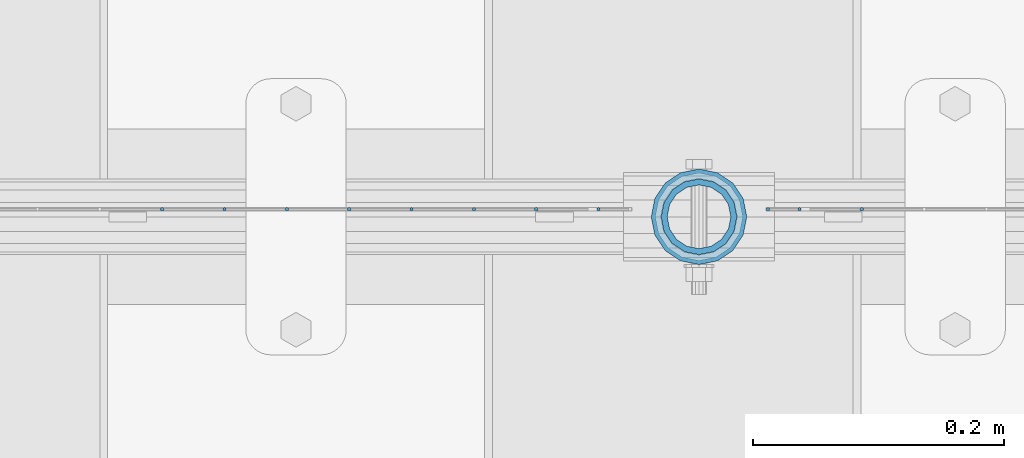
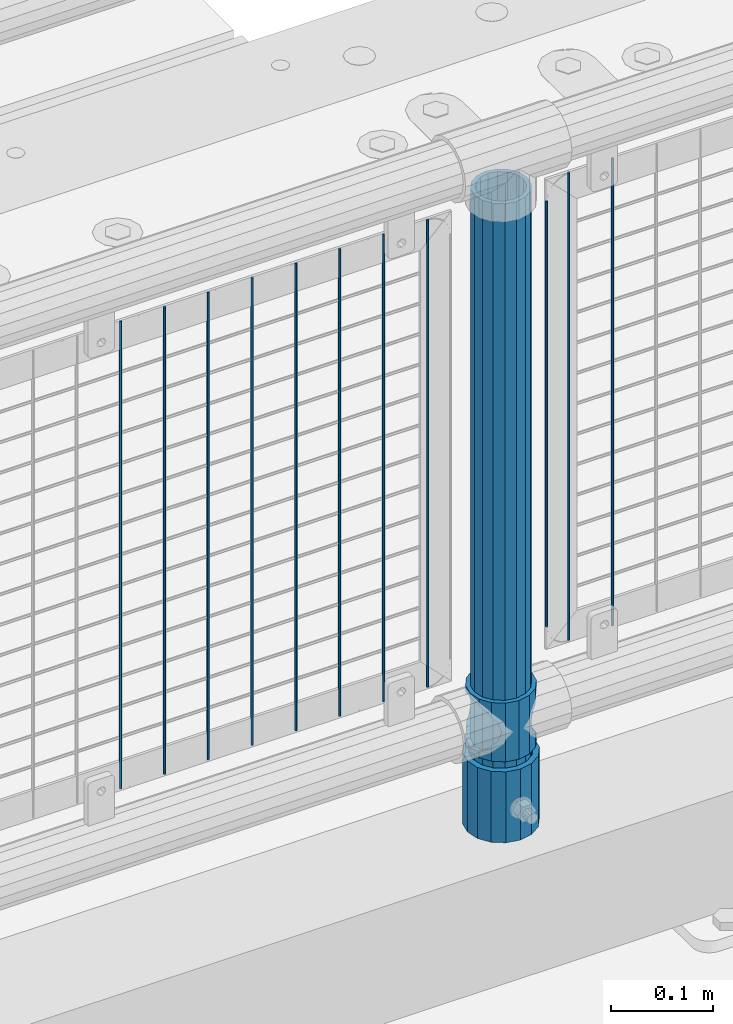
# One storey, part 77 of 208: 14 columns.
"""IFC2X3 building model written with IfcOpenShell, lengths in millimetres."""

from ifc_helpers import new_model, si_unit, frame, origin_with_axes, place, context, subcontext, project, spatial, faceted_brep, material, type_object, element, save


model = new_model("IFC2X3")

# Units and contexts
model_context = context("Model", 3, precision=1e-05, world=origin_with_axes())
body_context = subcontext(model_context, "Body", "Model", "MODEL_VIEW")
ifc_project = project(units=[si_unit("LENGTHUNIT", "METRE", prefix="MILLI"), si_unit("AREAUNIT", "SQUARE_METRE"), si_unit("VOLUMEUNIT", "CUBIC_METRE"), si_unit("MASSUNIT", "GRAM", prefix="KILO"), si_unit("TIMEUNIT", "SECOND"), si_unit("PLANEANGLEUNIT", "RADIAN"), si_unit("SOLIDANGLEUNIT", "STERADIAN"), si_unit("THERMODYNAMICTEMPERATUREUNIT", "DEGREE_CELSIUS"), si_unit("LUMINOUSINTENSITYUNIT", "LUMEN")], contexts=[model_context])

# Site, building, storey
site_placement = place(None, origin_with_axes())
site = spatial("IfcSite", under=ifc_project, at=site_placement, CompositionType="ELEMENT")
building_placement = place(site_placement, origin_with_axes())
building = spatial("IfcBuilding", under=site, at=building_placement, Name="Standard", CompositionType="ELEMENT")
storey_placement = place(building_placement, origin_with_axes())
storey = spatial("IfcBuildingStorey", under=building, at=storey_placement, Name="Undefined", CompositionType="ELEMENT", Elevation=0.0)

# Columns
ifc_material_1 = material()
column_type_1 = type_object("IfcColumnType", PredefinedType="NOTDEFINED")
column_1_placement = place(storey_placement, frame((-30629.0, 4664.5, 168.02), z_axis=(0.0, 1.0, 0.0), x_axis=(0.0, 0.0, 1.0)))
element("IfcColumn", 1, at=column_1_placement, inside=storey, type_object=column_type_1, material=ifc_material_1, context=body_context, shape_type="Brep", body=[
    faceted_brep([(0.0, -31.75, 0.0), (0.0, -29.3331751572332, 12.1501989775916), (85.0, -29.3331751572332, 12.1501989775916), (85.0, -31.75, 0.0), (0.0, -22.4506403026717, 22.4506403026726), (85.0, -22.4506403026717, 22.4506403026726), (0.0, -12.1501989775934, 29.3331751572332), (85.0, -12.1501989775934, 29.3331751572332), (0.0, 0.0, 31.75), (85.0, 0.0, 31.75), (0.0, 12.1501989775934, 29.3331751572332), (85.0, 12.1501989775934, 29.3331751572332), (0.0, 22.4506403026717, 22.4506403026726), (85.0, 22.4506403026717, 22.4506403026726), (0.0, 29.3331751572332, 12.1501989775916), (85.0, 29.3331751572332, 12.1501989775916), (0.0, 31.75, 0.0), (85.0, 31.75, 0.0), (0.0, 29.3331751572332, -12.1501989775916), (85.0, 29.3331751572332, -12.1501989775916), (0.0, 22.4506403026717, -22.4506403026726), (85.0, 22.4506403026717, -22.4506403026726), (0.0, 12.1501989775934, -29.3331751572332), (85.0, 12.1501989775934, -29.3331751572332), (0.0, 0.0, -31.75), (85.0, 0.0, -31.75), (0.0, -12.1501989775934, -29.3331751572332), (85.0, -12.1501989775934, -29.3331751572332), (0.0, -22.4506403026717, -22.4506403026726), (85.0, -22.4506403026717, -22.4506403026726), (0.0, -29.3331751572332, -12.1501989775916), (85.0, -29.3331751572332, -12.1501989775916), (0.0, -38.0499999999993, 0.0), (0.0, -35.1536162120537, -14.5611046014919), (85.0, -35.1536162120537, -14.5611046014919), (85.0, -38.0499999999993, 0.0), (0.0, -26.9054130241493, -26.9054130241484), (85.0, -26.9054130241493, -26.9054130241484), (0.0, -14.5611046014928, -35.1536162120547), (85.0, -14.5611046014928, -35.1536162120547), (0.0, 0.0, -38.0500000000002), (85.0, 0.0, -38.0500000000002), (0.0, 14.5611046014928, -35.1536162120547), (85.0, 14.5611046014928, -35.1536162120547), (0.0, 26.9054130241493, -26.9054130241484), (85.0, 26.9054130241493, -26.9054130241484), (0.0, 35.1536162120537, -14.5611046014919), (85.0, 35.1536162120537, -14.5611046014919), (0.0, 38.0499999999993, 0.0), (85.0, 38.0499999999993, 0.0), (0.0, 35.1536162120537, 14.5611046014919), (85.0, 35.1536162120537, 14.5611046014919), (0.0, 26.9054130241493, 26.9054130241484), (85.0, 26.9054130241493, 26.9054130241484), (0.0, 14.5611046014928, 35.1536162120547), (85.0, 14.5611046014928, 35.1536162120547), (0.0, 0.0, 38.0500000000002), (85.0, 0.0, 38.0500000000002), (0.0, -14.5611046014928, 35.1536162120547), (85.0, -14.5611046014928, 35.1536162120547), (0.0, -26.9054130241493, 26.9054130241484), (85.0, -26.9054130241493, 26.9054130241484), (0.0, -35.1536162120537, 14.5611046014919), (85.0, -35.1536162120537, 14.5611046014919)], [[[0, 1, 2, 3]], [[1, 4, 5, 2]], [[4, 6, 7, 5]], [[6, 8, 9, 7]], [[8, 10, 11, 9]], [[10, 12, 13, 11]], [[12, 14, 15, 13]], [[14, 16, 17, 15]], [[16, 18, 19, 17]], [[18, 20, 21, 19]], [[20, 22, 23, 21]], [[22, 24, 25, 23]], [[24, 26, 27, 25]], [[26, 28, 29, 27]], [[28, 30, 31, 29]], [[30, 0, 3, 31]], [[32, 33, 34, 35]], [[33, 36, 37, 34]], [[36, 38, 39, 37]], [[38, 40, 41, 39]], [[40, 42, 43, 41]], [[42, 44, 45, 43]], [[44, 46, 47, 45]], [[46, 48, 49, 47]], [[48, 50, 51, 49]], [[50, 52, 53, 51]], [[52, 54, 55, 53]], [[54, 56, 57, 55]], [[56, 58, 59, 57]], [[58, 60, 61, 59]], [[60, 62, 63, 61]], [[62, 32, 35, 63]], [[37, 39, 41, 43, 45, 47, 49, 51, 53, 55, 57, 59, 61, 63, 35, 34], [5, 7, 9, 11, 13, 15, 17, 19, 21, 23, 25, 27, 29, 31, 3, 2]], [[62, 60, 58, 56, 54, 52, 50, 48, 46, 44, 42, 40, 38, 36, 33, 32], [30, 28, 26, 24, 22, 20, 18, 16, 14, 12, 10, 8, 6, 4, 1, 0]]]),
])
ifc_material_2 = material(Name="Misc_Undefined")
column_type_2 = type_object("IfcColumnType", PredefinedType="NOTDEFINED")
column_2_placement = place(storey_placement, frame((-30629.0, 4664.5, 263.02), z_axis=(-1.0, 0.0, 0.0), x_axis=(0.0, 0.0, 1.0)))
element("IfcColumn", 2, at=column_2_placement, inside=storey, type_object=column_type_2, material=ifc_material_2, context=body_context, shape_type="Brep", body=[
    faceted_brep([(63.1897438117172, 11.6144421722802, -32.8397438117245), (63.1897438117172, 11.6144421722802, -28.0397438117143), (56.6106908090114, 21.4606908090118, -21.4606908090136), (56.6106908090114, 21.4606908090118, -27.1226768591077), (61.962379517676, 13.4513226476329, -32.4743655677739), (46.7644421722801, 28.0397438117179, -11.6144421722784), (46.7644421722801, 28.0397438117179, -20.0882031229921), (51.531042408003, 24.8548033587067, -24.8548033587067), (35.1500000000015, 30.35, 0.0), (35.1499999999996, 30.3500000000004, -16.6306603983685), (23.5355578277192, 28.0397438117179, -11.6144421722784), (23.5355578277192, 28.0397438117179, -20.0882031229921), (18.7689575919962, 24.8548033587067, -24.8548033587067), (13.6893091909879, 21.4606908090118, -21.4606908090136), (13.6893091909879, 21.4606908090118, -27.1226768591077), (8.33762048232325, 13.4513226476329, -32.4743655677739), (7.11025618828211, 11.6144421722802, -28.0397438117143), (7.11025618828211, 11.6144421722802, -32.8397438117245), (4.79999999999961, 0.0, -30.3499999999985), (4.79999999999961, 0.0, -35.1500000000015), (7.11025618828205, -11.6144421722802, -28.0397438117143), (7.11025618828205, -11.6144421722802, -32.8397438117245), (13.6893091909879, -21.4606908090118, -21.4606908090136), (13.6893091909879, -21.4606908090118, -27.1226768591005), (8.33762048232325, -13.4513226476329, -32.4743655677739), (23.5355578277191, -28.0397438117179, -11.6144421722784), (23.5355578277191, -28.0397438117179, -20.0882031229921), (18.7689575919962, -24.8548033587067, -24.8548033587067), (35.1500000000015, -30.35, 0.0), (35.1499999999996, -30.3500000000004, -16.6306603983685), (46.7644421722801, -28.0397438117179, -11.6144421722784), (46.7644421722801, -28.0397438117179, -20.0882031229921), (51.531042408003, -24.8548033587067, -24.8548033587067), (56.6106908090114, -21.4606908090118, -21.4606908090136), (56.6106908090114, -21.4606908090118, -27.1226768591005), (61.962379517675, -13.4513226476329, -32.4743655677739), (63.1897438117172, -11.6144421722802, -28.0397438117143), (63.1897438117172, -11.6144421722802, -32.8397438117245), (65.4999999999997, 0.0, -30.3499999999985), (65.4999999999997, 0.0, -35.1500000000015), (0.0, -28.0397438117179, -11.6144421722784), (0.0, -30.3500000000004, 0.0), (0.0, -21.4606908090118, -21.4606908090136), (0.0, -11.6144421722802, -28.0397438117143), (0.0, 0.0, -30.3499999999985), (0.0, 11.6144421722802, -28.0397438117143), (0.0, 21.4606908090118, -21.4606908090136), (0.0, 28.0397438117179, -11.6144421722784), (0.0, 30.3500000000004, 0.0), (0.0, 28.0397438117179, 11.6144421722784), (23.5355578277192, 28.0397438117179, 11.6144421722784), (0.0, 21.4606908090118, 21.4606908090136), (13.6893091909879, 21.4606908090118, 21.4606908090136), (0.0, 11.6144421722802, 28.0397438117143), (7.11025618828211, 11.6144421722802, 28.0397438117143), (0.0, 0.0, 30.3499999999985), (4.79999999999961, 0.0, 30.3499999999985), (0.0, -11.6144421722802, 28.0397438117143), (7.11025618828205, -11.6144421722802, 28.0397438117143), (0.0, -21.4606908090118, 21.4606908090136), (13.6893091909879, -21.4606908090118, 21.4606908090136), (0.0, -28.0397438117179, 11.6144421722784), (23.5355578277191, -28.0397438117179, 11.6144421722784), (0.0, -32.4743655677721, 13.4513226476338), (0.0, -35.1499999999996, 0.0), (70.2999999999993, -35.1499999999996, 0.0), (70.2999999999993, -32.4743655677721, 13.4513226476338), (0.0, 13.4513226476329, -32.4743655677739), (0.0, 24.8548033587067, -24.8548033587067), (0.0, 0.0, -35.1499999999996), (0.0, -13.4513226476329, -32.4743655677739), (0.0, -24.8548033587067, -24.8548033587067), (0.0, -24.8548033587067, 24.8548033587067), (0.0, -13.4513226476329, 32.4743655677739), (0.0, 0.0, 35.1499999999996), (0.0, 13.4513226476329, 32.4743655677739), (0.0, 24.8548033587067, 24.8548033587067), (0.0, 32.4743655677721, 13.4513226476338), (0.0, 35.1499999999996, 0.0), (0.0, 32.4743655677721, -13.4513226476338), (0.0, -32.4743655677721, -13.4513226476338), (70.2999999999993, 32.4743655677721, 13.4513226476338), (70.2999999999993, 35.1499999999996, 0.0), (70.2999999999993, 32.4743655677721, -13.4513226476338), (70.2999999999993, 24.8548033587067, -24.8548033587067), (70.2999999999993, 13.4513226476329, -32.4743655677739), (70.2999999999993, 0.0, -35.1500000000015), (70.2999999999993, -13.4513226476329, -32.4743655677739), (70.2999999999993, -24.8548033587067, -24.8548033587067), (70.2999999999993, -32.4743655677721, -13.4513226476338), (70.2999999999993, 28.0397438117179, 11.6144421722784), (70.2999999999993, 21.4606908090118, 21.4606908090136), (56.6106908090114, 21.4606908090118, 21.4606908090136), (46.7644421722801, 28.0397438117179, 11.6144421722784), (70.2999999999993, 11.6144421722802, 28.0397438117143), (63.1897438117172, 11.6144421722802, 28.0397438117143), (70.2999999999993, 0.0, 30.3499999999985), (65.4999999999997, 0.0, 30.3499999999985), (70.2999999999993, -11.6144421722802, 28.0397438117143), (63.1897438117172, -11.6144421722802, 28.0397438117143), (70.2999999999993, -21.4606908090118, 21.4606908090136), (56.6106908090114, -21.4606908090118, 21.4606908090136), (70.2999999999993, -28.0397438117179, 11.6144421722784), (46.7644421722801, -28.0397438117179, 11.6144421722784), (70.2999999999993, -11.6144421722802, -28.0397438117143), (70.2999999999993, 0.0, -30.3499999999985), (70.2999999999993, -21.4606908090118, -21.4606908090136), (70.2999999999993, -28.0397438117179, -11.6144421722784), (70.2999999999993, -30.3500000000004, 0.0), (70.2999999999993, 24.8548033587067, 24.8548033587067), (70.2999999999993, 13.4513226476329, 32.4743655677739), (70.2999999999993, 0.0, 35.1500000000015), (70.2999999999993, -13.4513226476329, 32.4743655677739), (70.2999999999993, -24.8548033587067, 24.8548033587067), (70.2999999999993, 30.3500000000004, 0.0), (70.2999999999993, 28.0397438117179, -11.6144421722784), (70.2999999999993, 21.4606908090118, -21.4606908090136), (70.2999999999993, 11.6144421722802, -28.0397438117143), (61.9623795176756, 13.4513226476329, 32.4743655677739), (51.531042408003, 24.8548033587067, 24.8548033587067), (56.6106908090114, 21.4606908090118, 27.1226768591005), (65.4999999999997, 0.0, 35.1500000000015), (63.1897438117172, 11.6144421722802, 32.8397438117172), (63.1897438117172, -11.6144421722802, 32.8397438117245), (61.962379517675, -13.4513226476329, 32.4743655677739), (56.6106908090114, -21.4606908090118, 27.1226768591077), (51.531042408003, -24.8548033587067, 24.8548033587067), (18.7689575919962, -24.8548033587067, 24.8548033587067), (46.7644421722801, -28.0397438117179, 20.0882031229776), (35.1499999999996, -30.3500000000004, 16.6306603983612), (23.5355578277191, -28.0397438117179, 20.0882031229776), (8.3376204823237, -13.4513226476329, 32.4743655677739), (13.6893091909879, -21.4606908090118, 27.1226768591077), (4.79999999999961, 0.0, 35.1500000000015), (7.11025618828205, -11.6144421722802, 32.8397438117245), (7.11025618828211, 11.6144421722802, 32.8397438117172), (8.3376204823237, 13.4513226476329, 32.4743655677739), (13.6893091909879, 21.4606908090118, 27.1226768591005), (18.7689575919962, 24.8548033587067, 24.8548033587067), (23.5355578277192, 28.0397438117179, 20.0882031229921), (35.1499999999996, 30.3500000000004, 16.6306603983685), (46.7644421722801, 28.0397438117179, 20.0882031229921)], [[[0, 1, 2, 3, 4]], [[3, 2, 5, 6, 7]], [[6, 5, 8, 9]], [[9, 8, 10, 11]], [[12, 11, 10, 13, 14]], [[15, 14, 13, 16, 17]], [[17, 16, 18, 19]], [[19, 18, 20, 21]], [[21, 20, 22, 23, 24]], [[23, 22, 25, 26, 27]], [[26, 25, 28, 29]], [[29, 28, 30, 31]], [[32, 31, 30, 33, 34]], [[35, 34, 33, 36, 37]], [[37, 36, 38, 39]], [[39, 38, 1, 0]], [[40, 41, 28, 25]], [[42, 40, 25, 22]], [[43, 42, 22, 20]], [[44, 43, 20, 18]], [[45, 44, 18, 16]], [[46, 45, 16, 13]], [[47, 46, 13, 10]], [[48, 47, 10, 8]], [[49, 48, 8, 50]], [[51, 49, 50, 52]], [[53, 51, 52, 54]], [[55, 53, 54, 56]], [[57, 55, 56, 58]], [[59, 57, 58, 60]], [[61, 59, 60, 62]], [[41, 61, 62, 28]], [[63, 64, 65, 66]], [[67, 68, 12, 14, 15]], [[69, 67, 15, 17, 19]], [[24, 70, 69, 19, 21]], [[27, 71, 70, 24, 23]], [[63, 72, 73, 74, 75, 76, 77, 78, 79, 68, 67, 69, 70, 71, 80, 64], [40, 42, 43, 44, 45, 46, 47, 48, 49, 51, 53, 55, 57, 59, 61, 41]], [[78, 77, 81, 82]], [[79, 78, 82, 83]], [[9, 11, 12, 68, 79, 83, 84, 7, 6]], [[7, 84, 85, 4, 3]], [[4, 85, 86, 39, 0]], [[87, 88, 32, 34, 35]], [[86, 87, 35, 37, 39]], [[88, 89, 80, 71, 27, 26, 29, 31, 32]], [[64, 80, 89, 65]], [[90, 91, 92, 93]], [[91, 94, 95, 92]], [[94, 96, 97, 95]], [[96, 98, 99, 97]], [[98, 100, 101, 99]], [[100, 102, 103, 101]], [[104, 105, 38, 36]], [[106, 104, 36, 33]], [[107, 106, 33, 30]], [[108, 107, 30, 28]], [[102, 108, 28, 103]], [[88, 87, 86, 85, 84, 83, 82, 81, 109, 110, 111, 112, 113, 66, 65, 89], [100, 98, 96, 94, 91, 90, 114, 115, 116, 117, 105, 104, 106, 107, 108, 102]], [[118, 110, 109, 119, 120]], [[121, 111, 110, 118, 122]], [[112, 111, 121, 123, 124]], [[113, 112, 124, 125, 126]], [[127, 72, 63, 66, 113, 126, 128, 129, 130]], [[131, 73, 72, 127, 132]], [[133, 74, 73, 131, 134]], [[75, 74, 133, 135, 136]], [[76, 75, 136, 137, 138]], [[119, 109, 81, 77, 76, 138, 139, 140, 141]], [[92, 120, 119, 141, 93]], [[95, 122, 118, 120, 92]], [[97, 121, 122, 95]], [[99, 123, 121, 97]], [[101, 125, 124, 123, 99]], [[103, 128, 126, 125, 101]], [[28, 129, 128, 103]], [[62, 130, 129, 28]], [[60, 132, 127, 130, 62]], [[58, 134, 131, 132, 60]], [[56, 133, 134, 58]], [[54, 135, 133, 56]], [[52, 137, 136, 135, 54]], [[50, 139, 138, 137, 52]], [[8, 140, 139, 50]], [[93, 141, 140, 8]], [[114, 90, 93, 8]], [[115, 114, 8, 5]], [[116, 115, 5, 2]], [[117, 116, 2, 1]], [[105, 117, 1, 38]]]),
])
column_type_3 = type_object("IfcColumnType", PredefinedType="NOTDEFINED")
column_3_placement = place(storey_placement, frame((-30629.0, 4664.5, 168.02), z_axis=(-1.0, 0.0, 0.0), x_axis=(0.0, 0.0, 1.0)))
element("IfcColumn", 3, at=column_3_placement, inside=storey, type_object=column_type_3, material=ifc_material_1, context=body_context, shape_type="Brep", body=[
    faceted_brep([(0.0, -25.3500000000004, 0.0), (0.0, -23.4203461491616, 9.70102501045403), (760.0, -23.4203461491616, 9.70102501045403), (760.0, -25.3500000000004, 0.0), (0.0, -17.9251569030794, 17.9251569030785), (760.0, -17.9251569030794, 17.9251569030785), (0.0, -9.70102501045494, 23.4203461491597), (760.0, -9.70102501045494, 23.4203461491597), (0.0, 0.0, 25.3499999999985), (760.0, 0.0, 25.3499999999985), (0.0, 9.70102501045494, 23.4203461491597), (760.0, 9.70102501045494, 23.4203461491597), (0.0, 17.9251569030794, 17.9251569030785), (760.0, 17.9251569030794, 17.9251569030785), (0.0, 23.4203461491616, 9.70102501045403), (760.0, 23.4203461491616, 9.70102501045403), (0.0, 25.3500000000004, 0.0), (760.0, 25.3500000000004, 0.0), (0.0, 23.4203461491616, -9.70102501045403), (760.0, 23.4203461491616, -9.70102501045403), (0.0, 17.9251569030794, -17.9251569030785), (760.0, 17.9251569030794, -17.9251569030785), (0.0, 9.70102501045494, -23.4203461491597), (760.0, 9.70102501045494, -23.4203461491597), (0.0, 0.0, -25.3499999999985), (760.0, 0.0, -25.3499999999985), (0.0, -9.70102501045494, -23.4203461491597), (760.0, -9.70102501045494, -23.4203461491597), (0.0, -17.9251569030794, -17.9251569030785), (760.0, -17.9251569030794, -17.9251569030785), (0.0, -23.4203461491616, -9.70102501045403), (760.0, -23.4203461491616, -9.70102501045403), (0.0, -30.1499999999996, 0.0), (0.0, -27.8549679052148, -11.5379054858058), (760.0, -27.8549679052148, -11.5379054858058), (760.0, -30.1499999999996, 0.0), (0.0, -21.3192694527743, -21.3192694527752), (760.0, -21.3192694527743, -21.3192694527752), (0.0, -11.5379054858076, -27.8549679052157), (760.0, -11.5379054858076, -27.8549679052157), (0.0, 0.0, -30.1500000000015), (760.0, 0.0, -30.1500000000015), (0.0, 11.5379054858076, -27.8549679052157), (760.0, 11.5379054858076, -27.8549679052157), (0.0, 21.3192694527743, -21.3192694527752), (760.0, 21.3192694527743, -21.3192694527752), (0.0, 27.8549679052157, -11.5379054858058), (760.0, 27.8549679052157, -11.5379054858058), (0.0, 30.1499999999996, 0.0), (760.0, 30.1499999999996, 0.0), (0.0, 27.8549679052157, 11.5379054858058), (760.0, 27.8549679052157, 11.5379054858058), (0.0, 21.3192694527743, 21.3192694527752), (760.0, 21.3192694527743, 21.3192694527752), (0.0, 11.5379054858076, 27.8549679052157), (760.0, 11.5379054858076, 27.8549679052157), (0.0, 0.0, 30.1500000000015), (760.0, 0.0, 30.1500000000015), (0.0, -11.5379054858076, 27.8549679052157), (760.0, -11.5379054858076, 27.8549679052157), (0.0, -21.3192694527743, 21.3192694527752), (760.0, -21.3192694527743, 21.3192694527752), (0.0, -27.8549679052157, 11.5379054858058), (760.0, -27.8549679052157, 11.5379054858058)], [[[0, 1, 2, 3]], [[1, 4, 5, 2]], [[4, 6, 7, 5]], [[6, 8, 9, 7]], [[8, 10, 11, 9]], [[10, 12, 13, 11]], [[12, 14, 15, 13]], [[14, 16, 17, 15]], [[16, 18, 19, 17]], [[18, 20, 21, 19]], [[20, 22, 23, 21]], [[22, 24, 25, 23]], [[24, 26, 27, 25]], [[26, 28, 29, 27]], [[28, 30, 31, 29]], [[30, 0, 3, 31]], [[32, 33, 34, 35]], [[33, 36, 37, 34]], [[36, 38, 39, 37]], [[38, 40, 41, 39]], [[40, 42, 43, 41]], [[42, 44, 45, 43]], [[44, 46, 47, 45]], [[46, 48, 49, 47]], [[48, 50, 51, 49]], [[50, 52, 53, 51]], [[52, 54, 55, 53]], [[54, 56, 57, 55]], [[56, 58, 59, 57]], [[58, 60, 61, 59]], [[60, 62, 63, 61]], [[62, 32, 35, 63]], [[37, 39, 41, 43, 45, 47, 49, 51, 53, 55, 57, 59, 61, 63, 35, 34], [5, 7, 9, 11, 13, 15, 17, 19, 21, 23, 25, 27, 29, 31, 3, 2]], [[62, 60, 58, 56, 54, 52, 50, 48, 46, 44, 42, 40, 38, 36, 33, 32], [30, 28, 26, 24, 22, 20, 18, 16, 14, 12, 10, 8, 6, 4, 1, 0]]]),
])
column_type_4 = type_object("IfcColumnType", Name="D3", PredefinedType="NOTDEFINED")
column_4_placement = place(storey_placement, frame((-30499.3448275862, 4670.50000000001, 353.020000000005), z_axis=(-0.999999999962839, 0.0, 8.62099999968473e-06), x_axis=(8.62099999949798e-06, 0.0, 0.999999999962839)))
element("IfcColumn", 4, at=column_4_placement, inside=storey, type_object=column_type_4, material=ifc_material_2, ObjectType="D3", context=body_context, shape_type="Brep", body=[
    faceted_brep([(0.0, -1.49999999999909, 3.63797880709171e-12), (-7.27595761418343e-12, -0.749999999999091, -1.29903810567669), (560.0, -0.75, -1.29903810567703), (560.0, -1.5, 0.0), (-3.63797880709171e-12, 0.750000000000909, -1.29903810567669), (560.0, 0.75, -1.29903810567703), (0.0, 1.50000000000182, 3.63797880709171e-12), (560.0, 1.5, 0.0), (-3.63797880709171e-12, 0.750000000000909, 1.29903810567669), (560.0, 0.75, 1.29903810567703), (-7.27595761418343e-12, -0.749999999999091, 1.29903810567669), (560.0, -0.75, 1.29903810567703)], [[[0, 1, 2, 3]], [[1, 4, 5, 2]], [[4, 6, 7, 5]], [[6, 8, 9, 7]], [[8, 10, 11, 9]], [[10, 0, 3, 11]], [[5, 7, 9, 11, 3, 2]], [[10, 8, 6, 4, 1, 0]]]),
])
column_5_placement = place(storey_placement, frame((-30574.0, 4670.50000000001, 378.020000000005), z_axis=(-1.0, 0.0, 0.0), x_axis=(0.0, 0.0, 1.0)))
element("IfcColumn", 5, at=column_5_placement, inside=storey, type_object=column_type_4, material=ifc_material_2, ObjectType="D3", context=body_context, shape_type="Brep", body=[
    faceted_brep([(0.0, -1.49999999999909, 3.63797880709171e-12), (-7.27595761418343e-12, -0.749999999999091, -1.29903810567669), (510.0, -0.75, -1.29903810567703), (510.0, -1.5, 0.0), (-3.63797880709171e-12, 0.750000000000909, -1.29903810567669), (510.0, 0.75, -1.29903810567703), (0.0, 1.50000000000182, 3.63797880709171e-12), (510.0, 1.5, 0.0), (-3.63797880709171e-12, 0.750000000000909, 1.29903810567669), (510.0, 0.75, 1.29903810567703), (-7.27595761418343e-12, -0.749999999999091, 1.29903810567669), (510.0, -0.75, 1.29903810567703)], [[[0, 1, 2, 3]], [[1, 4, 5, 2]], [[4, 6, 7, 5]], [[6, 8, 9, 7]], [[8, 10, 11, 9]], [[10, 0, 3, 11]], [[5, 7, 9, 11, 3, 2]], [[10, 8, 6, 4, 1, 0]]]),
])
for number, where, z_axis, x_axis in (
    (6, (-30549.0, 4670.50000000001, 353.020000000005), (-1.0, 0.0, 0.0), (0.0, 0.0, 1.0)),
    (7, (-30709.005, 4670.50000000001, 353.020000000004), (-1.0, 0.0, 0.0), (0.0, 0.0, 1.0)),
    (8, (-30758.66, 4670.50000000001, 353.020000000004), (-1.0, 0.0, 0.0), (0.0, 0.0, 1.0)),
    (9, (-30808.315, 4670.50000000001, 353.020000000004), (-1.0, 0.0, 0.0), (0.0, 0.0, 1.0)),
    (10, (-30857.97, 4670.50000000001, 353.020000000004), (-1.0, 0.0, 0.0), (0.0, 0.0, 1.0)),
    (11, (-30907.625, 4670.50000000001, 353.020000000004), (-1.0, 0.0, 0.0), (0.0, 0.0, 1.0)),
    (12, (-30957.28, 4670.50000000001, 353.020000000004), (-1.0, 0.0, 0.0), (0.0, 0.0, 1.0)),
    (13, (-31006.935, 4670.50000000001, 353.020000000004), (-1.0, 0.0, 0.0), (0.0, 0.0, 1.0)),
    (14, (-31056.59, 4670.50000000001, 353.020000000004), (-1.0, 0.0, 0.0), (0.0, 0.0, 1.0)),
):
    element("IfcColumn", number, at=place(storey_placement, frame(where, z_axis=z_axis, x_axis=x_axis)), inside=storey, type_object=column_type_4, material=ifc_material_2, ObjectType="D3", context=body_context, shape_type="Brep", body=[
        faceted_brep([(0.0, -1.49999999999909, 3.63797880709171e-12), (-7.27595761418343e-12, -0.749999999999091, -1.29903810567669), (560.0, -0.75, -1.29903810567703), (560.0, -1.5, 0.0), (-3.63797880709171e-12, 0.750000000000909, -1.29903810567669), (560.0, 0.75, -1.29903810567703), (0.0, 1.50000000000182, 3.63797880709171e-12), (560.0, 1.5, 0.0), (-3.63797880709171e-12, 0.750000000000909, 1.29903810567669), (560.0, 0.75, 1.29903810567703), (-7.27595761418343e-12, -0.749999999999091, 1.29903810567669), (560.0, -0.75, 1.29903810567703)], [[[0, 1, 2, 3]], [[1, 4, 5, 2]], [[4, 6, 7, 5]], [[6, 8, 9, 7]], [[8, 10, 11, 9]], [[10, 0, 3, 11]], [[5, 7, 9, 11, 3, 2]], [[10, 8, 6, 4, 1, 0]]]),
    ])

save(model, "model.ifc")
